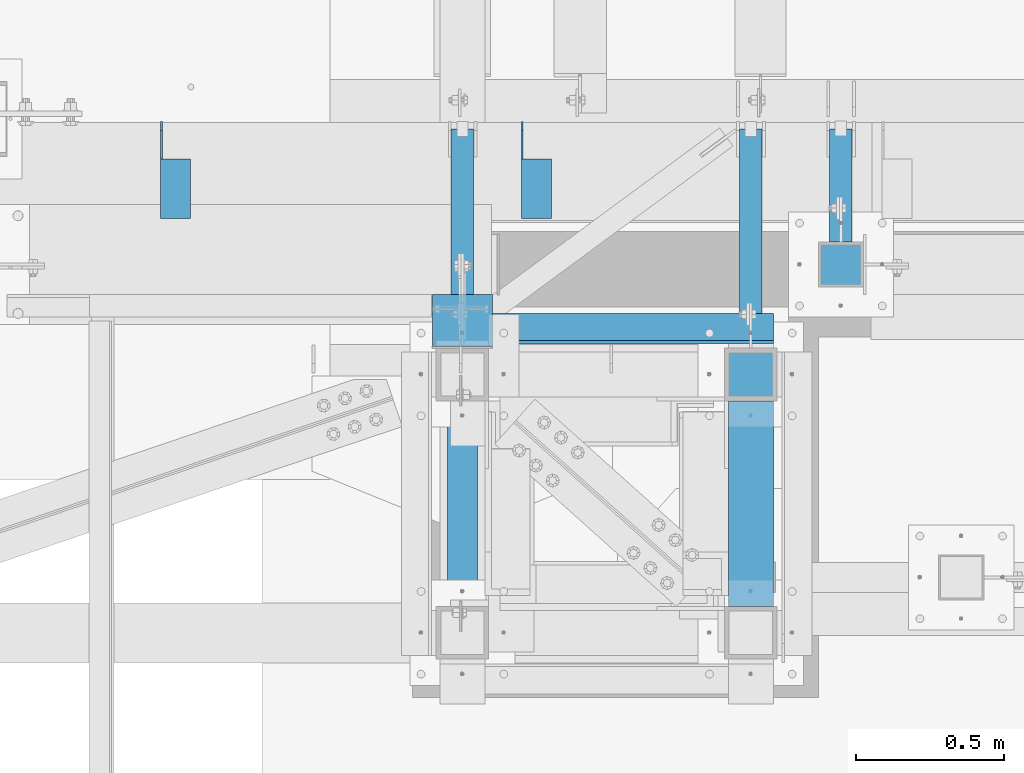
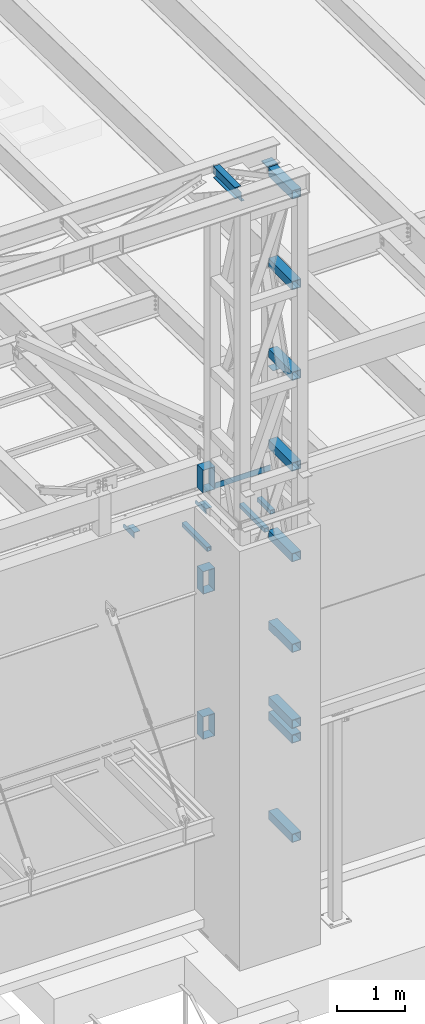
# One storey, part 1210 of 1763: 21 beams, 7 elements without a shape of their own.
"""IFC2X3 building model written with IfcOpenShell, lengths in millimetres."""

from ifc_helpers import new_model, si_unit, frame, origin_with_axes, place, context, subcontext, project, spatial, faceted_brep, material, type_object, element, aggregate, save


model = new_model("IFC2X3")

# Units and contexts
model_context = context("Model", 3, precision=1e-05, world=origin_with_axes())
body_context = subcontext(model_context, "Body", "Model", "MODEL_VIEW")
ifc_project = project(units=[si_unit("LENGTHUNIT", "METRE", prefix="MILLI"), si_unit("AREAUNIT", "SQUARE_METRE"), si_unit("VOLUMEUNIT", "CUBIC_METRE"), si_unit("MASSUNIT", "GRAM", prefix="KILO"), si_unit("TIMEUNIT", "SECOND"), si_unit("PLANEANGLEUNIT", "RADIAN"), si_unit("SOLIDANGLEUNIT", "STERADIAN"), si_unit("THERMODYNAMICTEMPERATUREUNIT", "DEGREE_CELSIUS"), si_unit("LUMINOUSINTENSITYUNIT", "LUMEN")], contexts=[model_context])

# Site, building, storey
site_placement = place(None, origin_with_axes())
site = spatial("IfcSite", under=ifc_project, at=site_placement, CompositionType="ELEMENT")
building_placement = place(site_placement, origin_with_axes())
building = spatial("IfcBuilding", under=site, at=building_placement, Name="Undefined", CompositionType="ELEMENT")
storey_placement = place(building_placement, origin_with_axes())
storey = spatial("IfcBuildingStorey", under=building, at=storey_placement, Name="Undefined", CompositionType="ELEMENT", Elevation=0.0)

# Assembly, beams
assembly_1_placement = place(storey_placement, origin_with_axes())
assembly_1 = element("IfcElementAssembly", 1, at=assembly_1_placement, inside=storey, Name="BEAM", AssemblyPlace="NOTDEFINED", PredefinedType="RIGID_FRAME")
ifc_material_1 = material(Name="STEEL/A36")
beam_type_1 = type_object("IfcBeamType", Name="L4X4X1/4", PredefinedType="NOTDEFINED")
beam_1_placement = place(assembly_1_placement, frame((-47485.6055562795, -13723.937318617, 12153.9), z_axis=(0.0, 0.0, -1.0), x_axis=(0.0, -1.0, 0.0)))
beam_1 = element("IfcBeam", 2, at=beam_1_placement, type_object=beam_type_1, material=ifc_material_1, Name="BRACE", ObjectType="L4X4X1/4", context=body_context, shape_type="Brep", body=[
    faceted_brep([(126.999999999967, 44.4499999999971, -25.4000000000069), (126.999999999967, 50.8000000000029, -25.4000000000069), (127.0, 50.7999999999993, -50.7999999999993), (127.0, -50.7999999999993, -50.7999999999993), (126.999999999965, -50.8000000000029, -44.4500000000007), (126.999999999965, 44.4499999999971, -44.4500000000007), (31.7499999999691, 44.4499999999971, -25.3999994277547), (31.7499999999691, 50.8000000000029, -25.3999994277547), (-1.81898940354586e-10, 44.4500000000371, 50.7999999999374), (-1.96450855582952e-10, 50.8000000000393, 50.7999999999374), (0.0, 50.8000000000029, 6.35000057224534), (0.0, 44.4499999999971, 6.35000057224534), (328.612481689444, 44.4499999999971, 50.7999999999993), (328.612481689444, 50.8000000000029, 50.7999999999993), (328.612512206997, 44.4499999999971, -44.4500000000007), (328.612512206997, -50.8000000000029, -44.4500000000007), (328.612512206997, -50.8000000000029, -50.7999999999993), (328.612512206997, 50.8000000000029, -50.7999999999993)], [[[0, 1, 2, 3, 4, 5]], [[6, 7, 1, 0]], [[8, 9, 10, 11]], [[9, 8, 12, 13]], [[12, 14, 15, 16, 17, 13]], [[15, 14, 5, 4]], [[16, 15, 4, 3]], [[17, 16, 3, 2]], [[10, 9, 13, 17, 2, 1, 7]], [[11, 10, 7, 6]], [[14, 12, 8, 11, 6, 0, 5]]]),
])
beam_2_placement = place(assembly_1_placement, frame((-48704.8055562795, -13723.9373186171, 12153.9), z_axis=(0.0, 0.0, -1.0), x_axis=(0.0, -1.0, 0.0)))
beam_2 = element("IfcBeam", 3, at=beam_2_placement, type_object=beam_type_1, material=ifc_material_1, Name="BRACE", ObjectType="L4X4X1/4", context=body_context, shape_type="Brep", body=[
    faceted_brep([(0.0, 44.4499999999971, 6.35000057224534), (0.0, 50.8000000000029, 6.35000057224534), (31.7499999999691, 50.8000000000029, -25.3999994277547), (31.7499999999691, 44.4499999999971, -25.3999994277547), (-1.96450855582952e-10, 50.8000000000393, 50.7999999999374), (-1.81898940354586e-10, 44.4500000000371, 50.7999999999374), (328.612481689444, 44.4499999999971, 50.7999999999993), (328.612481689444, 50.8000000000029, 50.7999999999993), (328.612512206997, -50.8000000000029, -50.7999999999993), (328.612512206997, -50.8000000000029, -44.4500000000007), (126.999999999965, -50.8000000000029, -44.4500000000007), (127.0, -50.7999999999993, -50.7999999999993), (328.612512206997, 50.8000000000029, -50.7999999999993), (127.0, 50.7999999999993, -50.7999999999993), (328.612512206997, 44.4499999999971, -44.4500000000007), (126.999999999965, 44.4499999999971, -44.4500000000007), (126.999999999967, 44.4499999999971, -25.4000000000069), (126.999999999967, 50.8000000000029, -25.4000000000069)], [[[0, 1, 2, 3]], [[4, 5, 6, 7]], [[8, 9, 10, 11]], [[12, 8, 11, 13]], [[6, 14, 9, 8, 12, 7]], [[9, 14, 15, 10]], [[16, 17, 13, 11, 10, 15]], [[3, 2, 17, 16]], [[1, 4, 7, 12, 13, 17, 2]], [[5, 4, 1, 0]], [[14, 6, 5, 0, 3, 16, 15]]]),
])
aggregate(assembly_1, [beam_1, beam_2])

# Assembly, beam
assembly_2_placement = place(storey_placement, origin_with_axes())
assembly_2 = element("IfcElementAssembly", 4, at=assembly_2_placement, inside=storey, Name="BEAM", AssemblyPlace="NOTDEFINED", PredefinedType="RIGID_FRAME")
ifc_material_2 = material()
beam_type_2 = type_object("IfcBeamType", Name="HSS3X3X1/4", PredefinedType="NOTDEFINED")
beam_3_placement = place(assembly_2_placement, frame((-46456.4555979689, -14131.9264769908, 11820.525), z_axis=(0.0, 0.0, 1.0), x_axis=(0.0, 1.0, 0.0)))
beam_3 = element("IfcBeam", 5, at=beam_3_placement, type_object=beam_type_2, material=ifc_material_2, Name="BEAM", ObjectType="HSS3X3X1/4", context=body_context, shape_type="Brep", body=[
    faceted_brep([(0.0, 31.75, -31.75), (0.0, -31.75, -31.75), (382.589158373732, -31.75, -31.75), (382.589158373732, 31.75, -31.75), (0.0, -31.75, 31.75), (382.589158373732, -31.75, 31.75), (0.0, 31.75, 31.75), (382.589158373732, 31.75, 31.75), (0.0, 38.0999999999985, -38.1000000000004), (0.0, 38.0999999999985, 38.1000000000004), (382.589158373732, 38.0999999999985, 38.1000000000004), (382.589158373732, 38.0999999999985, -38.1000000000004), (0.0, -38.0999999999985, 38.1000000000004), (382.589158373732, -38.0999999999985, 38.1000000000004), (0.0, -38.0999999999985, -38.1000000000004), (382.589158373732, -38.0999999999985, -38.1000000000004)], [[[0, 1, 2, 3]], [[1, 4, 5, 2]], [[4, 6, 7, 5]], [[6, 0, 3, 7]], [[8, 9, 10, 11]], [[9, 12, 13, 10]], [[12, 14, 15, 13]], [[14, 8, 11, 15]], [[13, 15, 11, 10], [5, 7, 3, 2]], [[14, 12, 9, 8], [6, 4, 1, 0]]]),
])
aggregate(assembly_2, [beam_3])

assembly_3_placement = place(storey_placement, origin_with_axes())
assembly_3 = element("IfcElementAssembly", 6, at=assembly_3_placement, inside=storey, Name="BEAM", AssemblyPlace="NOTDEFINED", PredefinedType="RIGID_FRAME")
beam_4_placement = place(assembly_3_placement, frame((-46760.8272044142, -14490.7022094127, 11820.525), z_axis=(0.0, 0.0, 1.0), x_axis=(0.0, 1.0, 0.0)))
beam_4 = element("IfcBeam", 7, at=beam_4_placement, type_object=beam_type_2, material=ifc_material_2, Name="BEAM", ObjectType="HSS3X3X1/4", context=body_context, shape_type="Brep", body=[
    faceted_brep([(0.0, 31.75, -31.75), (0.0, -31.75, -31.75), (741.364890795607, -31.75, -31.75), (741.364890795607, 31.75, -31.75), (0.0, -31.75, 31.75), (741.364890795607, -31.75, 31.75), (0.0, 31.75, 31.75), (741.364890795607, 31.75, 31.75), (0.0, 38.0999999999985, -38.1000000000004), (0.0, 38.0999999999985, 38.1000000000004), (741.364890795607, 38.0999999999985, 38.1000000000004), (741.364890795607, 38.0999999999985, -38.1000000000004), (0.0, -38.0999999999985, 38.1000000000004), (741.364890795607, -38.0999999999985, 38.1000000000004), (0.0, -38.0999999999985, -38.1000000000004), (741.364890795607, -38.0999999999985, -38.1000000000004)], [[[0, 1, 2, 3]], [[1, 4, 5, 2]], [[4, 6, 7, 5]], [[6, 0, 3, 7]], [[8, 9, 10, 11]], [[9, 12, 13, 10]], [[12, 14, 15, 13]], [[14, 8, 11, 15]], [[13, 15, 11, 10], [5, 7, 3, 2]], [[14, 12, 9, 8], [6, 4, 1, 0]]]),
])
aggregate(assembly_3, [beam_4])

assembly_4_placement = place(storey_placement, origin_with_axes())
assembly_4 = element("IfcElementAssembly", 8, at=assembly_4_placement, inside=storey, Name="BEAM", AssemblyPlace="NOTDEFINED", PredefinedType="RIGID_FRAME")
beam_5_placement = place(assembly_4_placement, frame((-47735.5523997267, -14490.7022094127, 11820.525), z_axis=(0.0, 0.0, 1.0), x_axis=(0.0, 1.0, 0.0)))
beam_5 = element("IfcBeam", 9, at=beam_5_placement, type_object=beam_type_2, material=ifc_material_2, Name="BEAM", ObjectType="HSS3X3X1/4", context=body_context, shape_type="Brep", body=[
    faceted_brep([(0.0, 31.75, -31.75), (0.0, -31.75, -31.75), (741.364890795607, -31.75, -31.75), (741.364890795607, 31.75, -31.75), (0.0, -31.75, 31.75), (741.364890795607, -31.75, 31.75), (0.0, 31.75, 31.75), (741.364890795607, 31.75, 31.75), (0.0, 38.0999999999985, -38.1000000000004), (0.0, 38.0999999999985, 38.1000000000004), (741.364890795607, 38.0999999999985, 38.1000000000004), (741.364890795607, 38.0999999999985, -38.1000000000004), (0.0, -38.0999999999985, 38.1000000000004), (741.364890795607, -38.0999999999985, 38.1000000000004), (0.0, -38.0999999999985, -38.1000000000004), (741.364890795607, -38.0999999999985, -38.1000000000004)], [[[0, 1, 2, 3]], [[1, 4, 5, 2]], [[4, 6, 7, 5]], [[6, 0, 3, 7]], [[8, 9, 10, 11]], [[9, 12, 13, 10]], [[12, 14, 15, 13]], [[14, 8, 11, 15]], [[13, 15, 11, 10], [5, 7, 3, 2]], [[14, 12, 9, 8], [6, 4, 1, 0]]]),
])
aggregate(assembly_4, [beam_5])

# Assembly, beams
assembly_5_placement = place(storey_placement, origin_with_axes())
assembly_5 = element("IfcElementAssembly", 10, at=assembly_5_placement, inside=storey, Name="FRAME", AssemblyPlace="NOTDEFINED", PredefinedType="RIGID_FRAME")
beam_type_3 = type_object("IfcBeamType", Name="HSS6X6X3/8", PredefinedType="NOTDEFINED")
beam_6_placement = place(assembly_5_placement, frame((-46760.8272044142, -15452.7272094127, 8890.0), z_axis=(0.0, 0.0, 1.0), x_axis=(0.0, 1.0, 0.0)))
beam_6 = element("IfcBeam", 11, at=beam_6_placement, type_object=beam_type_3, material=ifc_material_2, Name="BEAM", ObjectType="HSS6X6X3/8", context=body_context, shape_type="Brep", body=[
    faceted_brep([(88.8999999999996, 66.6750000000029, -66.6749999999993), (88.8999999999996, -66.6750000000029, -66.6749999999993), (784.225, -66.6750000000029, -66.6749999999993), (784.225, 66.6750000000029, -66.6749999999993), (88.8999999999996, -66.6750000000029, 66.6749999999993), (784.225, -66.6750000000029, 66.6749999999993), (88.8999999999996, 66.6750000000029, 66.6749999999993), (784.225, 66.6750000000029, 66.6749999999993), (88.8999999999996, 76.1999999999971, -76.2000000000007), (88.8999999999996, 76.1999999999971, 76.2000000000007), (784.225, 76.1999999999971, 76.2000000000007), (784.225, 76.1999999999971, -76.2000000000007), (88.8999999999996, -76.1999999999971, 76.2000000000007), (784.225, -76.1999999999971, 76.2000000000007), (88.8999999999996, -76.1999999999971, -76.2000000000007), (784.225, -76.1999999999971, -76.2000000000007)], [[[0, 1, 2, 3]], [[1, 4, 5, 2]], [[4, 6, 7, 5]], [[6, 0, 3, 7]], [[8, 9, 10, 11]], [[9, 12, 13, 10]], [[12, 14, 15, 13]], [[14, 8, 11, 15]], [[13, 15, 11, 10], [5, 7, 3, 2]], [[14, 12, 9, 8], [6, 4, 1, 0]]]),
])
beam_7_placement = place(assembly_5_placement, frame((-46760.8272038619, -15452.7271102113, 10248.70156), z_axis=(0.0, 0.0, 1.0), x_axis=(0.0, 1.0, 0.0)))
beam_7 = element("IfcBeam", 12, at=beam_7_placement, type_object=beam_type_3, material=ifc_material_2, Name="BEAM", ObjectType="HSS6X6X3/8", context=body_context, shape_type="Brep", body=[
    faceted_brep([(88.8999008650717, 66.6749999997191, -66.6749999999993), (88.8999007322054, -66.6750000002794, -66.6749999999993), (784.224900732206, -66.6750000025058, -66.6749999999993), (784.224900865072, 66.6749999974927, -66.6749999999993), (88.8999007322054, -66.6750000002794, 66.6749999999993), (784.224900732206, -66.6750000025058, 66.6749999999993), (88.8999008650717, 66.6749999997191, 66.6749999999993), (784.224900865072, 66.6749999974927, 66.6749999999993), (88.8999008745614, 76.1999999997206, -76.2000000000007), (88.8999008745614, 76.1999999997206, 76.2000000000007), (784.224900874562, 76.1999999974942, 76.2000000000007), (784.224900874562, 76.1999999974942, -76.2000000000007), (88.8999007227158, -76.2000000002809, 76.2000000000007), (784.224900722716, -76.2000000025073, 76.2000000000007), (88.8999007227158, -76.2000000002809, -76.2000000000007), (784.224900722716, -76.2000000025073, -76.2000000000007)], [[[0, 1, 2, 3]], [[1, 4, 5, 2]], [[4, 6, 7, 5]], [[6, 0, 3, 7]], [[8, 9, 10, 11]], [[9, 12, 13, 10]], [[12, 14, 15, 13]], [[14, 8, 11, 15]], [[13, 15, 11, 10], [5, 7, 3, 2]], [[14, 12, 9, 8], [6, 4, 1, 0]]]),
])
beam_8_placement = place(assembly_5_placement, frame((-46760.8272038619, -15452.7271102113, 11873.706248), z_axis=(0.0, 0.0, 1.0), x_axis=(0.0, 1.0, 0.0)))
beam_8 = element("IfcBeam", 13, at=beam_8_placement, type_object=beam_type_3, material=ifc_material_2, Name="BEAM", ObjectType="HSS6X6X3/8", context=body_context, shape_type="Brep", body=[
    faceted_brep([(88.8999008650717, 66.6749999997191, -66.6749999999993), (88.8999007322054, -66.6750000002794, -66.6749999999993), (784.224900732206, -66.6750000025058, -66.6749999999993), (784.224900865072, 66.6749999974927, -66.6749999999993), (88.8999007322054, -66.6750000002794, 66.6749999999993), (784.224900732206, -66.6750000025058, 66.6749999999993), (88.8999008650717, 66.6749999997191, 66.6749999999993), (784.224900865072, 66.6749999974927, 66.6749999999993), (88.8999008745614, 76.1999999997206, -76.2000000000007), (88.8999008745614, 76.1999999997206, 76.2000000000007), (784.224900874562, 76.1999999974942, 76.2000000000007), (784.224900874562, 76.1999999974942, -76.2000000000007), (88.8999007227158, -76.2000000002809, 76.2000000000007), (784.224900722716, -76.2000000025073, 76.2000000000007), (88.8999007227158, -76.2000000002809, -76.2000000000007), (784.224900722716, -76.2000000025073, -76.2000000000007)], [[[0, 1, 2, 3]], [[1, 4, 5, 2]], [[4, 6, 7, 5]], [[6, 0, 3, 7]], [[8, 9, 10, 11]], [[9, 12, 13, 10]], [[12, 14, 15, 13]], [[14, 8, 11, 15]], [[13, 15, 11, 10], [5, 7, 3, 2]], [[14, 12, 9, 8], [6, 4, 1, 0]]]),
])
beam_9_placement = place(assembly_5_placement, frame((-46760.8272038619, -15452.7271102113, 13498.710936), z_axis=(0.0, 0.0, 1.0), x_axis=(0.0, 1.0, 0.0)))
beam_9 = element("IfcBeam", 14, at=beam_9_placement, type_object=beam_type_3, material=ifc_material_2, Name="BEAM", ObjectType="HSS6X6X3/8", context=body_context, shape_type="Brep", body=[
    faceted_brep([(88.8999008650717, 66.6749999997191, -66.6749999999993), (88.8999007322054, -66.6750000002794, -66.6749999999993), (784.224900732206, -66.6750000025058, -66.6749999999993), (784.224900865072, 66.6749999974927, -66.6749999999993), (88.8999007322054, -66.6750000002794, 66.6749999999993), (784.224900732206, -66.6750000025058, 66.6749999999993), (88.8999008650717, 66.6749999997191, 66.6749999999993), (784.224900865072, 66.6749999974927, 66.6749999999993), (88.8999008745614, 76.1999999997206, -76.2000000000007), (88.8999008745614, 76.1999999997206, 76.2000000000007), (784.224900874562, 76.1999999974942, 76.2000000000007), (784.224900874562, 76.1999999974942, -76.2000000000007), (88.8999007227158, -76.2000000002809, 76.2000000000007), (784.224900722716, -76.2000000025073, 76.2000000000007), (88.8999007227158, -76.2000000002809, -76.2000000000007), (784.224900722716, -76.2000000025073, -76.2000000000007)], [[[0, 1, 2, 3]], [[1, 4, 5, 2]], [[4, 6, 7, 5]], [[6, 0, 3, 7]], [[8, 9, 10, 11]], [[9, 12, 13, 10]], [[12, 14, 15, 13]], [[14, 8, 11, 15]], [[13, 15, 11, 10], [5, 7, 3, 2]], [[14, 12, 9, 8], [6, 4, 1, 0]]]),
])
beam_10_placement = place(assembly_5_placement, frame((-46760.8272038619, -15452.7271102113, 15123.715624), z_axis=(0.0, 0.0, 1.0), x_axis=(0.0, 1.0, 0.0)))
beam_10 = element("IfcBeam", 15, at=beam_10_placement, type_object=beam_type_3, material=ifc_material_2, Name="BEAM", ObjectType="HSS6X6X3/8", context=body_context, shape_type="Brep", body=[
    faceted_brep([(88.8999008650717, 66.6749999997191, -66.6749999999993), (88.8999007322054, -66.6750000002794, -66.6749999999993), (784.224900732206, -66.6750000025058, -66.6749999999993), (784.224900865072, 66.6749999974927, -66.6749999999993), (88.8999007322054, -66.6750000002794, 66.6749999999993), (784.224900732206, -66.6750000025058, 66.6749999999993), (88.8999008650717, 66.6749999997191, 66.6749999999993), (784.224900865072, 66.6749999974927, 66.6749999999993), (88.8999008745614, 76.1999999997206, -76.2000000000007), (88.8999008745614, 76.1999999997206, 76.2000000000007), (784.224900874562, 76.1999999974942, 76.2000000000007), (784.224900874562, 76.1999999974942, -76.2000000000007), (88.8999007227158, -76.2000000002809, 76.2000000000007), (784.224900722716, -76.2000000025073, 76.2000000000007), (88.8999007227158, -76.2000000002809, -76.2000000000007), (784.224900722716, -76.2000000025073, -76.2000000000007)], [[[0, 1, 2, 3]], [[1, 4, 5, 2]], [[4, 6, 7, 5]], [[6, 0, 3, 7]], [[8, 9, 10, 11]], [[9, 12, 13, 10]], [[12, 14, 15, 13]], [[14, 8, 11, 15]], [[13, 15, 11, 10], [5, 7, 3, 2]], [[14, 12, 9, 8], [6, 4, 1, 0]]]),
])
beam_11_placement = place(assembly_5_placement, frame((-46760.8272038619, -15452.7271102113, 16748.720312), z_axis=(0.0, 0.0, 1.0), x_axis=(0.0, 1.0, 0.0)))
beam_11 = element("IfcBeam", 16, at=beam_11_placement, type_object=beam_type_3, material=ifc_material_2, Name="BEAM", ObjectType="HSS6X6X3/8", context=body_context, shape_type="Brep", body=[
    faceted_brep([(88.8999008650717, 66.6749999997191, -66.6749999999993), (88.8999007322054, -66.6750000002794, -66.6749999999993), (784.224900732206, -66.6750000025058, -66.6749999999993), (784.224900865072, 66.6749999974927, -66.6749999999993), (88.8999007322054, -66.6750000002794, 66.6749999999993), (784.224900732206, -66.6750000025058, 66.6749999999993), (88.8999008650717, 66.6749999997191, 66.6749999999993), (784.224900865072, 66.6749999974927, 66.6749999999993), (88.8999008745614, 76.1999999997206, -76.2000000000007), (88.8999008745614, 76.1999999997206, 76.2000000000007), (784.224900874562, 76.1999999974942, 76.2000000000007), (784.224900874562, 76.1999999974942, -76.2000000000007), (88.8999007227158, -76.2000000002809, 76.2000000000007), (784.224900722716, -76.2000000025073, 76.2000000000007), (88.8999007227158, -76.2000000002809, -76.2000000000007), (784.224900722716, -76.2000000025073, -76.2000000000007)], [[[0, 1, 2, 3]], [[1, 4, 5, 2]], [[4, 6, 7, 5]], [[6, 0, 3, 7]], [[8, 9, 10, 11]], [[9, 12, 13, 10]], [[12, 14, 15, 13]], [[14, 8, 11, 15]], [[13, 15, 11, 10], [5, 7, 3, 2]], [[14, 12, 9, 8], [6, 4, 1, 0]]]),
])
beam_12_placement = place(assembly_5_placement, frame((-46760.8272038619, -15452.7271102113, 18373.725), z_axis=(0.0, 0.0, 1.0), x_axis=(0.0, 1.0, 0.0)))
beam_12 = element("IfcBeam", 17, at=beam_12_placement, type_object=beam_type_3, material=ifc_material_2, Name="BEAM", ObjectType="HSS6X6X3/8", context=body_context, shape_type="Brep", body=[
    faceted_brep([(88.8999008650717, 66.6749999997191, -66.6749999999993), (88.8999007322054, -66.6750000002794, -66.6749999999993), (784.224900732206, -66.6750000025058, -66.6749999999993), (784.224900865072, 66.6749999974927, -66.6749999999993), (88.8999007322054, -66.6750000002794, 66.6749999999993), (784.224900732206, -66.6750000025058, 66.6749999999993), (88.8999008650717, 66.6749999997191, 66.6749999999993), (784.224900865072, 66.6749999974927, 66.6749999999993), (88.8999008745614, 76.1999999997206, -76.2000000000007), (88.8999008745614, 76.1999999997206, 76.2000000000007), (784.224900874562, 76.1999999974942, 76.2000000000007), (784.224900874562, 76.1999999974942, -76.2000000000007), (88.8999007227158, -76.2000000002809, 76.2000000000007), (784.224900722716, -76.2000000025073, 76.2000000000007), (88.8999007227158, -76.2000000002809, -76.2000000000007), (784.224900722716, -76.2000000025073, -76.2000000000007)], [[[0, 1, 2, 3]], [[1, 4, 5, 2]], [[4, 6, 7, 5]], [[6, 0, 3, 7]], [[8, 9, 10, 11]], [[9, 12, 13, 10]], [[12, 14, 15, 13]], [[14, 8, 11, 15]], [[13, 15, 11, 10], [5, 7, 3, 2]], [[14, 12, 9, 8], [6, 4, 1, 0]]]),
])
beam_13_placement = place(assembly_5_placement, frame((-46760.8272044142, -15452.7272094127, 8623.3), z_axis=(0.0, 0.0, 1.0), x_axis=(0.0, 1.0, 0.0)))
beam_13 = element("IfcBeam", 18, at=beam_13_placement, type_object=beam_type_3, material=ifc_material_2, Name="BEAM", ObjectType="HSS6X6X3/8", context=body_context, shape_type="Brep", body=[
    faceted_brep([(88.8999999999996, 66.6750000000029, -66.6749999999993), (88.8999999999996, -66.6750000000029, -66.6749999999993), (784.225, -66.6750000000029, -66.6749999999993), (784.225, 66.6750000000029, -66.6749999999993), (88.8999999999996, -66.6750000000029, 66.6749999999993), (784.225, -66.6750000000029, 66.6749999999993), (88.8999999999996, 66.6750000000029, 66.6749999999993), (784.225, 66.6750000000029, 66.6749999999993), (88.8999999999996, 76.1999999999971, -76.2000000000007), (88.8999999999996, 76.1999999999971, 76.2000000000007), (784.225, 76.1999999999971, 76.2000000000007), (784.225, 76.1999999999971, -76.2000000000007), (88.8999999999996, -76.1999999999971, 76.2000000000007), (784.225, -76.1999999999971, 76.2000000000007), (88.8999999999996, -76.1999999999971, -76.2000000000007), (784.225, -76.1999999999971, -76.2000000000007)], [[[0, 1, 2, 3]], [[1, 4, 5, 2]], [[4, 6, 7, 5]], [[6, 0, 3, 7]], [[8, 9, 10, 11]], [[9, 12, 13, 10]], [[12, 14, 15, 13]], [[14, 8, 11, 15]], [[13, 15, 11, 10], [5, 7, 3, 2]], [[14, 12, 9, 8], [6, 4, 1, 0]]]),
])
beam_14_placement = place(assembly_5_placement, frame((-46760.8272044142, -15452.7272094127, 6845.3), z_axis=(0.0, 0.0, 1.0), x_axis=(0.0, 1.0, 0.0)))
beam_14 = element("IfcBeam", 19, at=beam_14_placement, type_object=beam_type_3, material=ifc_material_2, Name="BEAM", ObjectType="HSS6X6X3/8", context=body_context, shape_type="Brep", body=[
    faceted_brep([(88.8999999999996, 66.6750000000029, -66.6749999999993), (88.8999999999996, -66.6750000000029, -66.6749999999993), (784.225, -66.6750000000029, -66.6749999999993), (784.225, 66.6750000000029, -66.6749999999993), (88.8999999999996, -66.6750000000029, 66.6749999999993), (784.225, -66.6750000000029, 66.6749999999993), (88.8999999999996, 66.6750000000029, 66.6749999999993), (784.225, 66.6750000000029, 66.6749999999993), (88.8999999999996, 76.1999999999971, -76.2000000000007), (88.8999999999996, 76.1999999999971, 76.2000000000007), (784.225, 76.1999999999971, 76.2000000000007), (784.225, 76.1999999999971, -76.2000000000007), (88.8999999999996, -76.1999999999971, 76.2000000000007), (784.225, -76.1999999999971, 76.2000000000007), (88.8999999999996, -76.1999999999971, -76.2000000000007), (784.225, -76.1999999999971, -76.2000000000007)], [[[0, 1, 2, 3]], [[1, 4, 5, 2]], [[4, 6, 7, 5]], [[6, 0, 3, 7]], [[8, 9, 10, 11]], [[9, 12, 13, 10]], [[12, 14, 15, 13]], [[14, 8, 11, 15]], [[13, 15, 11, 10], [5, 7, 3, 2]], [[14, 12, 9, 8], [6, 4, 1, 0]]]),
])
beam_type_4 = type_object("IfcBeamType", Name="L4X4X3/8", PredefinedType="NOTDEFINED")
beam_15_placement = place(assembly_5_placement, frame((-47633.9512157379, -14424.0272094127, 12903.2221257819), z_axis=(0.0, 1.0, 0.0), x_axis=(0.999999999728392, 0.0, -2.33069999937009e-05)))
beam_15 = element("IfcBeam", 20, at=beam_15_placement, type_object=beam_type_4, material=ifc_material_1, Name="ANGLE", ObjectType="L4X4X3/8", context=body_context, shape_type="Brep", body=[
    faceted_brep([(-3.63797880709171e-11, 50.8000000000011, -50.8000000000538), (-1.96450855582952e-10, 50.8000000000393, 50.7999999999374), (949.325195572463, 50.8000000004577, 50.7999999999993), (949.325195572463, 50.8000000004577, -50.7999999999993), (0.0, 41.2749999999996, 50.7999999999993), (949.325195572485, 41.2750000004526, 50.7999999999993), (0.0, 41.2749999999996, -41.2750000000015), (949.325195572485, 41.2750000004526, -41.2749999999996), (0.0, -50.7999999999993, -41.2750000000015), (949.325195572696, -50.7999999996009, -41.2749999999996), (2.11002770811319e-10, -50.8000000000357, -50.799999999952), (949.325195572696, -50.7999999996009, -50.7999999999993)], [[[0, 1, 2, 3]], [[1, 4, 5, 2]], [[4, 6, 7, 5]], [[6, 8, 9, 7]], [[8, 10, 11, 9]], [[10, 0, 3, 11]], [[5, 7, 9, 11, 3, 2]], [[10, 8, 6, 4, 1, 0]]]),
])
beam_type_5 = type_object("IfcBeamType", Name="HSS16X8X1/4", PredefinedType="NOTDEFINED")
beam_16_placement = place(assembly_5_placement, frame((-47735.5523995934, -14490.7022106463, 13055.6221257957), z_axis=(0.0, 0.0, 1.0), x_axis=(0.0, 1.0, 0.0)))
beam_16 = element("IfcBeam", 21, at=beam_16_placement, type_object=beam_type_5, material=ifc_material_2, Name="BEAM", ObjectType="HSS16X8X1/4", context=body_context, shape_type="Brep", body=[
    faceted_brep([(6.35000009548457, 95.2499999999854, -196.85), (6.3499999048563, -95.2500000000146, -196.85), (180.974623664668, -95.2500000005748, -196.85), (180.974623664586, 95.2499999994252, -196.85), (6.3499999048563, -95.2500000000146, 196.85), (180.974623664668, -95.2500000005748, 196.85), (6.35000009548457, 95.2499999999854, 196.85), (180.974623664586, 95.2499999994252, 196.85), (6.35000010184012, 101.599999999984, -203.200000000001), (6.35000010184012, 101.599999999984, 203.200000000001), (180.974623664582, 101.599999999424, 203.200000000001), (180.974623664582, 101.599999999424, -203.200000000001), (6.34999989850257, -101.600000000013, 203.200000000001), (180.974623664672, -101.600000000581, 203.200000000001), (6.34999989850257, -101.600000000013, -203.200000000001), (180.974623664672, -101.600000000581, -203.200000000001)], [[[0, 1, 2, 3]], [[1, 4, 5, 2]], [[4, 6, 7, 5]], [[6, 0, 3, 7]], [[8, 9, 10, 11]], [[9, 12, 13, 10]], [[12, 14, 15, 13]], [[14, 8, 11, 15]], [[13, 15, 11, 10], [5, 7, 3, 2]], [[14, 12, 9, 8], [6, 4, 1, 0]]]),
])
beam_17_placement = place(assembly_5_placement, frame((-47735.5523997267, -14490.7022094127, 11239.5), z_axis=(0.0, 0.0, 1.0), x_axis=(0.0, 1.0, 0.0)))
beam_17 = element("IfcBeam", 22, at=beam_17_placement, type_object=beam_type_5, material=ifc_material_2, Name="BEAM", ObjectType="HSS16X8X1/4", context=body_context, shape_type="Brep", body=[
    faceted_brep([(6.35000009548457, 95.2499999999854, -196.85), (6.3499999048563, -95.2500000000146, -196.85), (180.974623664668, -95.2500000005748, -196.85), (180.974623664586, 95.2499999994252, -196.85), (6.3499999048563, -95.2500000000146, 196.85), (180.974623664668, -95.2500000005748, 196.85), (6.35000009548457, 95.2499999999854, 196.85), (180.974623664586, 95.2499999994252, 196.85), (6.35000010184012, 101.599999999984, -203.200000000001), (6.35000010184012, 101.599999999984, 203.200000000001), (180.974623664582, 101.599999999424, 203.200000000001), (180.974623664582, 101.599999999424, -203.200000000001), (6.34999989850257, -101.600000000013, 203.200000000001), (180.974623664672, -101.600000000581, 203.200000000001), (6.34999989850257, -101.600000000013, -203.200000000001), (180.974623664672, -101.600000000581, -203.200000000001)], [[[0, 1, 2, 3]], [[1, 4, 5, 2]], [[4, 6, 7, 5]], [[6, 0, 3, 7]], [[8, 9, 10, 11]], [[9, 12, 13, 10]], [[12, 14, 15, 13]], [[14, 8, 11, 15]], [[13, 15, 11, 10], [5, 7, 3, 2]], [[14, 12, 9, 8], [6, 4, 1, 0]]]),
])
beam_18_placement = place(assembly_5_placement, frame((-47735.5523997267, -14490.7022094127, 8636.0), z_axis=(0.0, 0.0, 1.0), x_axis=(0.0, 1.0, 0.0)))
beam_18 = element("IfcBeam", 23, at=beam_18_placement, type_object=beam_type_5, material=ifc_material_2, Name="BEAM", ObjectType="HSS16X8X1/4", context=body_context, shape_type="Brep", body=[
    faceted_brep([(6.35000009548457, 95.2499999999854, -196.85), (6.3499999048563, -95.2500000000146, -196.85), (180.974623664668, -95.2500000005748, -196.85), (180.974623664586, 95.2499999994252, -196.85), (6.3499999048563, -95.2500000000146, 196.85), (180.974623664668, -95.2500000005748, 196.85), (6.35000009548457, 95.2499999999854, 196.85), (180.974623664586, 95.2499999994252, 196.85), (6.35000010184012, 101.599999999984, -203.200000000001), (6.35000010184012, 101.599999999984, 203.200000000001), (180.974623664582, 101.599999999424, 203.200000000001), (180.974623664582, 101.599999999424, -203.200000000001), (6.34999989850257, -101.600000000013, 203.200000000001), (180.974623664672, -101.600000000581, 203.200000000001), (6.34999989850257, -101.600000000013, -203.200000000001), (180.974623664672, -101.600000000581, -203.200000000001)], [[[0, 1, 2, 3]], [[1, 4, 5, 2]], [[4, 6, 7, 5]], [[6, 0, 3, 7]], [[8, 9, 10, 11]], [[9, 12, 13, 10]], [[12, 14, 15, 13]], [[14, 8, 11, 15]], [[13, 15, 11, 10], [5, 7, 3, 2]], [[14, 12, 9, 8], [6, 4, 1, 0]]]),
])

# Assembly, beam
assembly_6_placement = place(storey_placement, origin_with_axes())
assembly_6 = element("IfcElementAssembly", 24, at=assembly_6_placement, inside=storey, Name="BEAM", AssemblyPlace="NOTDEFINED", PredefinedType="RIGID_FRAME")
ifc_material_3 = material(Name="STEEL/A992")
beam_type_6 = type_object("IfcBeamType", Name="W8X10", PredefinedType="NOTDEFINED")
beam_19_placement = place(assembly_6_placement, frame((-47735.5523997267, -15452.7272094127, 18721.3875), z_axis=(0.0, 0.0, 1.0), x_axis=(0.0, 1.0, 0.0)))
beam_19 = element("IfcBeam", 25, at=beam_19_placement, type_object=beam_type_6, material=ifc_material_3, Name="BEAM", ObjectType="W8X10", context=body_context, shape_type="Brep", body=[
    faceted_brep([(119.062498656618, 2.68111417606997, -95.25), (119.062498656122, 2.68138260961859, -100.012500000001), (17.4624005994319, 2.68119505581853, -100.012500000001), (17.4624005994319, 2.68092662227718, -95.25), (119.062409829083, 50.8000000000684, -95.25), (119.062409829083, 50.8000000000684, -100.012500000001), (119.062400602106, -2.38124999993306, 74.3525014877341), (119.062400602104, 2.38125000006403, 74.3525014877341), (118.095670679517, 2.38125000006403, 69.4924219696877), (118.095670679519, -2.38124999993306, 69.4924219696877), (115.342656779039, 2.38125000006403, 65.3722455015341), (115.342656779039, -2.38124999994034, 65.3722455015341), (111.222480310886, 2.38125000005675, 62.6192316010565), (111.222480310886, -2.38124999994034, 62.6192316010565), (106.362400792839, 2.38125000005675, 61.652501678469), (106.362400792841, -2.38124999994761, 61.652501678469), (17.4624005997321, 2.38125000000582, 61.652501678469), (17.4624373812949, -2.3812500000422, 61.652501678469), (17.4624373812949, -2.3812500000422, -95.25), (855.662438966074, -2.38125000246509, -95.25), (855.662438966074, -2.38125000246509, 61.652501678469), (766.762400411368, -2.38124999959837, 61.652501678469), (761.902320893321, -2.38124999959109, 62.6192316010565), (757.782144425168, -2.38124999959837, 65.3722455015341), (755.02913052469, -2.38124999959837, 69.4924219696877), (754.062400602103, -2.38124999959837, 74.3525014877341), (754.062400602103, -2.38124999959837, 95.25), (119.062400602106, -2.38124999993306, 95.25), (17.462400652912, -50.7999999999884, -95.25), (855.662400652911, -50.7999999995445, -95.25), (17.462400652912, -50.7999999999884, -100.012500000001), (855.662400652911, -50.7999999995445, -100.012500000001), (754.062294184512, 2.68138279386767, -95.25), (754.062294185007, 2.68111436032632, -100.012500000001), (754.062205357626, 50.8000000004031, -100.012500000001), (754.062205357626, 50.8000000004031, -95.25), (855.662400599429, 2.68157034747856, -95.25), (855.662400599429, 2.68130191392993, -100.012500000001), (855.662400599731, 2.38125000045693, -95.25), (855.662400599731, 2.38125000045693, 61.652501678469), (766.762400411366, 2.381250000406, 61.652501678469), (761.902320893321, 2.381250000406, 62.6192316010565), (757.782144425168, 2.381250000406, 65.3722455015341), (755.029130524688, 2.38125000039872, 69.4924219696877), (754.062400602101, 2.38125000039872, 74.3525014877341), (754.06240060213, -50.7999999996027, 100.012500000001), (754.06240060213, -50.7999999996027, 95.25), (754.062400602101, 2.38125000039872, 95.25), (754.062400602073, 50.8000000004031, 95.25), (754.062400602073, 50.8000000004031, 100.012500000001), (119.062400602104, 2.38125000006403, 95.25), (119.062400602077, 50.8000000000684, 95.25), (119.062400602077, 50.8000000000684, 100.012500000001), (119.062400602133, -50.7999999999374, 100.012500000001), (119.062400602133, -50.7999999999374, 95.25), (17.4624005997321, 2.38125000000582, -95.25)], [[[0, 1, 2, 3]], [[4, 5, 1, 0]], [[6, 7, 8, 9]], [[9, 8, 10, 11]], [[11, 10, 12, 13]], [[13, 12, 14, 15]], [[15, 14, 16, 17]], [[9, 11, 13, 15, 17, 18, 19, 20, 21, 22, 23, 24, 25, 26, 27, 6]], [[18, 28, 29, 19]], [[28, 30, 31, 29]], [[32, 33, 34, 35]], [[36, 37, 33, 32]], [[38, 39, 20, 19, 29, 31, 37, 36]], [[20, 39, 40, 21]], [[21, 40, 41, 22]], [[22, 41, 42, 23]], [[23, 42, 43, 24]], [[24, 43, 44, 25]], [[45, 46, 26, 25, 44, 47, 48, 49]], [[48, 47, 50, 51]], [[49, 48, 51, 52]], [[45, 49, 52, 53]], [[46, 45, 53, 54]], [[26, 46, 54, 27]], [[53, 52, 51, 50, 7, 6, 27, 54]], [[47, 44, 43, 42, 41, 40, 39, 38, 55, 16, 14, 12, 10, 8, 7, 50]], [[30, 28, 18, 17, 16, 55, 3, 2]], [[34, 33, 37, 31, 30, 2, 1, 5]], [[35, 34, 5, 4]], [[55, 38, 36, 32, 35, 4, 0, 3]]]),
])
aggregate(assembly_6, [beam_19])

assembly_7_placement = place(storey_placement, origin_with_axes())
assembly_7 = element("IfcElementAssembly", 26, at=assembly_7_placement, inside=storey, Name="COLUMN", AssemblyPlace="NOTDEFINED", PredefinedType="RIGID_FRAME")
beam_type_7 = type_object("IfcBeamType", PredefinedType="NOTDEFINED")
beam_20_placement = place(assembly_7_placement, frame((-46456.4555979689, -14284.3264769908, 14462.125), z_axis=(1.0, 0.0, 0.0), x_axis=(0.0, 1.0, 0.0)))
beam_20 = element("IfcBeam", 27, at=beam_20_placement, type_object=beam_type_7, material=ifc_material_1, Name="PLATE", context=body_context, shape_type="Brep", body=[
    faceted_brep([(0.0, 3.17500000001746, -76.2000000000007), (-1.51339918375015e-09, 3.17499999999927, 76.1999969482422), (152.399990844715, 3.17500000000291, 76.2000000000007), (152.399990844715, 3.17500000000291, -76.2000000000007), (-1.51339918375015e-09, -3.17499999999927, 76.1999969482422), (152.399990844715, -3.17500000000291, 76.2000000000007), (0.0, -3.17500000000291, -76.2000000000007), (152.399990844715, -3.17500000000291, -76.2000000000007)], [[[0, 1, 2, 3]], [[1, 4, 5, 2]], [[4, 6, 7, 5]], [[6, 0, 3, 7]], [[5, 7, 3, 2]], [[6, 4, 1, 0]]]),
])
aggregate(assembly_7, [beam_20])

# Beam
beam_type_8 = type_object("IfcBeamType", PredefinedType="NOTDEFINED")
beam_21_placement = place(assembly_5_placement, frame((-46760.8272044142, -14668.5022094127, 18459.45), z_axis=(1.0, 0.0, 0.0), x_axis=(0.0, 1.0, 0.0)))
beam_21 = element("IfcBeam", 28, at=beam_21_placement, type_object=beam_type_8, material=ifc_material_1, Name="PLATE", context=body_context, shape_type="Brep", body=[
    faceted_brep([(0.0, 9.52500000000146, -88.9000000000015), (0.0, 9.52500000000146, 88.9000000000015), (177.799999999999, 9.52500000000146, 88.9000000000015), (177.799999999999, 9.52500000000146, -88.9000000000015), (0.0, -9.52500000000146, 88.9000000000015), (177.799999999999, -9.52500000000146, 88.9000000000015), (0.0, -9.52500000000146, -88.9000000000015), (177.799999999999, -9.52500000000146, -88.9000000000015)], [[[0, 1, 2, 3]], [[1, 4, 5, 2]], [[4, 6, 7, 5]], [[6, 0, 3, 7]], [[5, 7, 3, 2]], [[6, 4, 1, 0]]]),
])

aggregate(assembly_5, [beam_6, beam_7, beam_8, beam_9, beam_10, beam_11, beam_12, beam_13, beam_14, beam_15, beam_21, beam_16, beam_17, beam_18])

save(model, "model.ifc")
